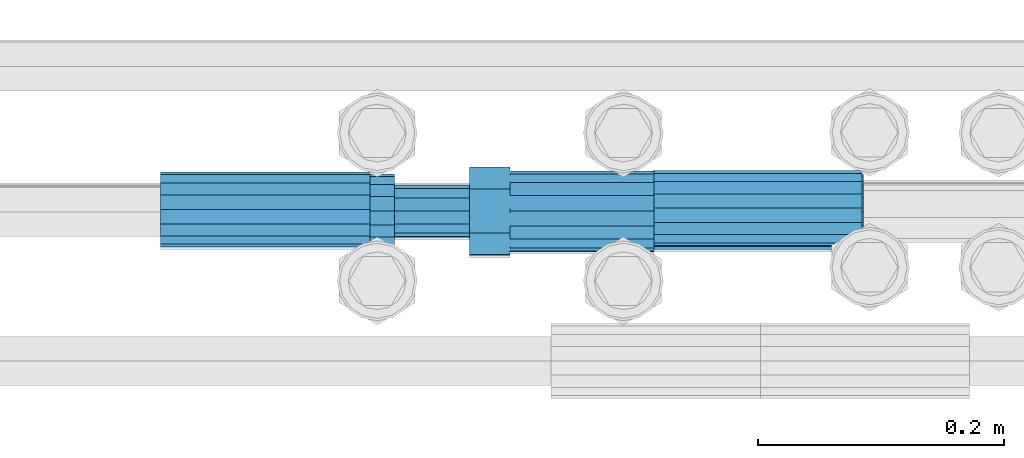
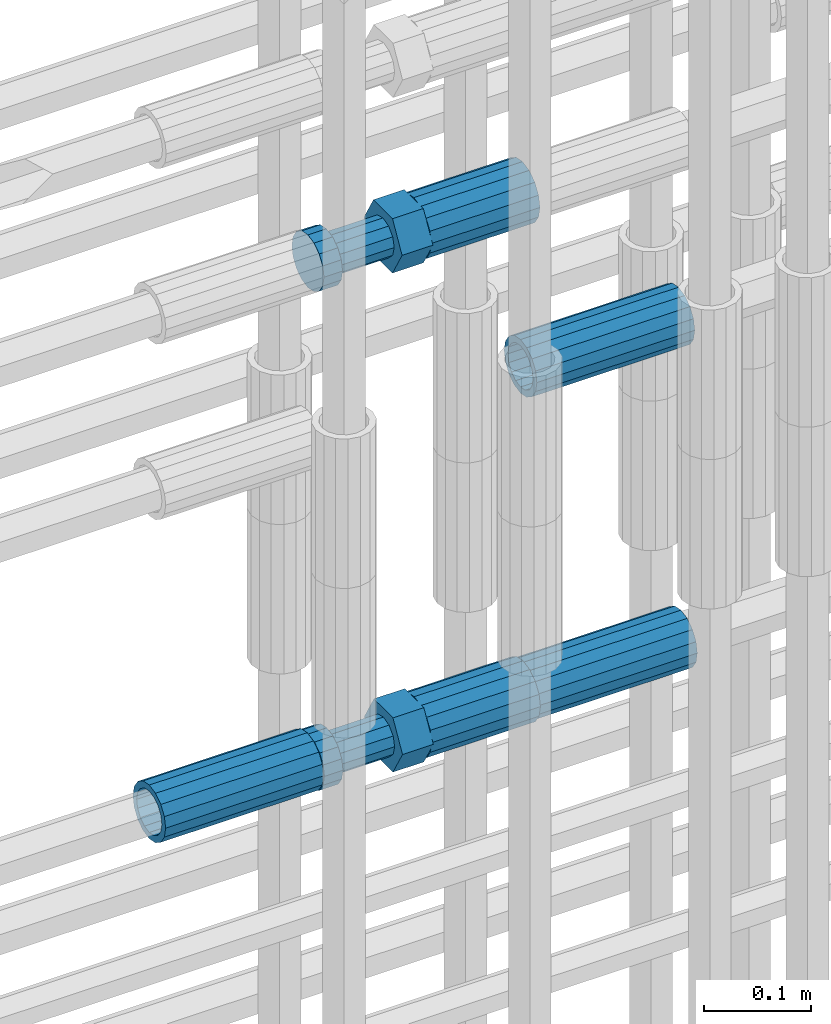
# One storey, part 42 of 119: 5 beams.
"""IFC2X3 building model written with IfcOpenShell, lengths in millimetres."""

from ifc_helpers import new_model, si_unit, frame, origin_with_axes, place, context, subcontext, project, spatial, faceted_brep, material, type_object, element, save


model = new_model("IFC2X3")

# Units and contexts
model_context = context("Model", 3, precision=1e-05, world=origin_with_axes())
body_context = subcontext(model_context, "Body", "Model", "MODEL_VIEW")
ifc_project = project(units=[si_unit("LENGTHUNIT", "METRE", prefix="MILLI"), si_unit("AREAUNIT", "SQUARE_METRE"), si_unit("VOLUMEUNIT", "CUBIC_METRE"), si_unit("MASSUNIT", "GRAM", prefix="KILO"), si_unit("TIMEUNIT", "SECOND"), si_unit("PLANEANGLEUNIT", "RADIAN"), si_unit("SOLIDANGLEUNIT", "STERADIAN"), si_unit("THERMODYNAMICTEMPERATUREUNIT", "DEGREE_CELSIUS"), si_unit("LUMINOUSINTENSITYUNIT", "LUMEN")], contexts=[model_context])

# Site, building, storey
site_placement = place(None, origin_with_axes())
site = spatial("IfcSite", under=ifc_project, at=site_placement, CompositionType="ELEMENT")
building_placement = place(site_placement, origin_with_axes())
building = spatial("IfcBuilding", under=site, at=building_placement, Name="Undefined", CompositionType="ELEMENT")
storey_placement = place(building_placement, origin_with_axes())
storey = spatial("IfcBuildingStorey", under=building, at=storey_placement, Name="Undefined", CompositionType="ELEMENT", Elevation=0.0)

# Beams
ifc_material = material(Name="STEEL/S275")
beam_type_1 = type_object("IfcBeamType", PredefinedType="NOTDEFINED")
beam_1_placement = place(storey_placement, frame((2035518.99345925, 6206284.98777132, 19955.1168409388), z_axis=(0.0, 0.0, 1.0), x_axis=(-0.99999999999998, 1.98000110685822e-07, 0.0)))
element("IfcBeam", 1, at=beam_1_placement, inside=storey, type_object=beam_type_1, material=ifc_material, Name="AG40N", context=body_context, shape_type="Brep", body=[
    faceted_brep([(1.62981450557709e-09, -23.4999999990687, 0.0), (7.45058059692383e-09, -21.7111690142192, 8.99306066057534), (170.000002125278, -21.711168999318, 8.99306066022245), (170.000002127141, -23.4999999844003, -3.66071617463604e-10), (4.65661287307739e-09, -16.6170093587134, 16.6170093578889), (170.000002122484, -16.6170093440451, 16.6170093575288), (1.86264514923096e-09, -8.99306066217832, 21.7111690140277), (170.000002118759, -8.99306064750999, 21.7111690136603), (2.3283064365387e-10, 9.31322574615479e-10, 23.5), (170.000002114102, 1.28056854009628e-08, 23.4999999996485), (-6.51925802230835e-09, 8.99306065868586, 21.7111690140241), (170.00000211224, 8.99306067335419, 21.7111690136639), (-7.45058059692383e-09, 16.6170093561523, 16.6170093578853), (170.000002109446, 16.6170093708206, 16.6170093575324), (-9.31322574615479e-09, 21.711169013055, 8.99306066057534), (170.000002108514, 21.7111690277234, 8.99306066022245), (-1.16415321826935e-09, 23.5000000009313, 0.0), (170.000002108514, 23.5000000144355, -3.66071617463604e-10), (-8.38190317153931e-09, 21.7111690151505, -8.99306066059444), (170.000002110377, 21.7111690300517, -8.9930606609546), (-5.58793544769287e-09, 16.6170093598776, -16.6170093579008), (170.000002113171, 16.6170093745459, -16.6170093582609), (-9.31322574615479e-10, 8.99306066334248, -21.7111690140396), (170.000002115965, 8.99306067801081, -21.7111690143961), (2.3283064365387e-10, 9.31322574615479e-10, -23.5), (170.00000211969, 1.7927959561348e-08, -23.5000000003843), (5.58793544769287e-09, -8.99306065752171, -21.7111690140396), (170.000002123415, -8.99306064285338, -21.7111690143961), (8.38190317153931e-09, -16.6170093549881, -16.6170093579008), (170.000002125278, -16.6170093403198, -16.6170093582646), (9.31322574615479e-09, -21.7111690121237, -8.99306066059444), (170.000002127141, -21.7111689972226, -8.9930606609546), (1.11758708953857e-08, -30.4999999990687, -9.54969436861575e-12), (1.30385160446167e-08, -28.1783257392235, -11.6718446871514), (170.000002129003, -28.1783257243223, -11.6718446875116), (170.000002129935, -30.4999999841675, -3.66071617463604e-10), (1.02445483207703e-08, -21.5667568228673, -21.5667568262129), (170.000002128072, -21.566756808199, -21.5667568265694), (7.45058059692383e-09, -11.6718446831219, -28.1783257416196), (170.000002125278, -11.6718446684536, -28.1783257419834), (3.72529029846191e-09, 3.95812094211578e-09, -30.5000000000277), (170.00000211969, 1.83936208486557e-08, -30.5000000003879), (-9.31322574615479e-10, 11.6718446905725, -28.1783257416232), (170.000002115965, 11.6718447052408, -28.1783257419797), (-6.51925802230835e-09, 21.5667568286881, -21.5667568262093), (170.000002110377, 21.5667568433564, -21.5667568265694), (-9.31322574615479e-09, 28.178325742716, -11.6718446871478), (170.000002108514, 28.1783257573843, -11.6718446875079), (-1.21071934700012e-08, 30.5, -5.91171556152403e-12), (170.000002106652, 30.5000000144355, -3.62433638656512e-10), (-1.21071934700012e-08, 28.1783257401548, 11.6718446871359), (170.00000210572, 28.1783257548232, 11.6718446867794), (-1.02445483207703e-08, 21.5667568240315, 21.5667568261974), (170.000002107583, 21.566756838467, 21.5667568258409), (-7.45058059692383e-09, 11.671844684286, 28.1783257416041), (170.000002110377, 11.6718446989544, 28.178325741244), (-2.79396772384644e-09, -2.56113708019257e-09, 30.5000000000159), (170.000002114102, 1.18743628263474e-08, 30.4999999996558), (1.86264514923096e-09, -11.6718446896411, 28.1783257416114), (170.000002118759, -11.67184467474, 28.178325741244), (7.45058059692383e-09, -21.5667568275239, 21.5667568261974), (170.000002123415, -21.5667568126228, 21.5667568258373), (1.02445483207703e-08, -28.1783257415518, 11.6718446871359), (170.000002127141, -28.1783257271163, 11.6718446867794)], [[[0, 1, 2, 3]], [[1, 4, 5, 2]], [[4, 6, 7, 5]], [[6, 8, 9, 7]], [[8, 10, 11, 9]], [[10, 12, 13, 11]], [[12, 14, 15, 13]], [[14, 16, 17, 15]], [[16, 18, 19, 17]], [[18, 20, 21, 19]], [[20, 22, 23, 21]], [[22, 24, 25, 23]], [[24, 26, 27, 25]], [[26, 28, 29, 27]], [[28, 30, 31, 29]], [[30, 0, 3, 31]], [[32, 33, 34, 35]], [[33, 36, 37, 34]], [[36, 38, 39, 37]], [[38, 40, 41, 39]], [[40, 42, 43, 41]], [[42, 44, 45, 43]], [[44, 46, 47, 45]], [[46, 48, 49, 47]], [[48, 50, 51, 49]], [[50, 52, 53, 51]], [[52, 54, 55, 53]], [[54, 56, 57, 55]], [[56, 58, 59, 57]], [[58, 60, 61, 59]], [[60, 62, 63, 61]], [[62, 32, 35, 63]], [[37, 39, 41, 43, 45, 47, 49, 51, 53, 55, 57, 59, 61, 63, 35, 34], [5, 7, 9, 11, 13, 15, 17, 19, 21, 23, 25, 27, 29, 31, 3, 2]], [[62, 60, 58, 56, 54, 52, 50, 48, 46, 44, 42, 40, 38, 36, 33, 32], [30, 28, 26, 24, 22, 20, 18, 16, 14, 12, 10, 8, 6, 4, 1, 0]]]),
])
beam_2_placement = place(storey_placement, frame((2035519.99345925, 6206282.01777132, 19589.2468409389), z_axis=(0.0, 0.0, 1.0), x_axis=(-0.99999999999998, 1.98000110685822e-07, 0.0)))
element("IfcBeam", 2, at=beam_2_placement, inside=storey, type_object=beam_type_1, material=ifc_material, Name="AG40N", context=body_context, shape_type="Brep", body=[
    faceted_brep([(1.62981450557709e-09, -23.4999999990687, 0.0), (7.45058059692383e-09, -21.7111690142192, 8.99306066057534), (170.000002125278, -21.711168999318, 8.99306066022245), (170.000002127141, -23.4999999844003, -3.66071617463604e-10), (4.65661287307739e-09, -16.6170093587134, 16.6170093578889), (170.000002122484, -16.6170093440451, 16.6170093575288), (1.86264514923096e-09, -8.99306066217832, 21.7111690140277), (170.000002118759, -8.99306064750999, 21.7111690136603), (2.3283064365387e-10, 9.31322574615479e-10, 23.5), (170.000002114102, 1.28056854009628e-08, 23.4999999996485), (-6.51925802230835e-09, 8.99306065868586, 21.7111690140241), (170.00000211224, 8.99306067335419, 21.7111690136639), (-7.45058059692383e-09, 16.6170093561523, 16.6170093578853), (170.000002109446, 16.6170093708206, 16.6170093575324), (-9.31322574615479e-09, 21.711169013055, 8.99306066057534), (170.000002108514, 21.7111690277234, 8.99306066022245), (-1.16415321826935e-09, 23.5000000009313, 0.0), (170.000002108514, 23.5000000144355, -3.66071617463604e-10), (-8.38190317153931e-09, 21.7111690151505, -8.99306066059444), (170.000002110377, 21.7111690300517, -8.9930606609546), (-5.58793544769287e-09, 16.6170093598776, -16.6170093579008), (170.000002113171, 16.6170093745459, -16.6170093582609), (-9.31322574615479e-10, 8.99306066334248, -21.7111690140396), (170.000002115965, 8.99306067801081, -21.7111690143961), (2.3283064365387e-10, 9.31322574615479e-10, -23.5), (170.00000211969, 1.7927959561348e-08, -23.5000000003843), (5.58793544769287e-09, -8.99306065752171, -21.7111690140396), (170.000002123415, -8.99306064285338, -21.7111690143961), (8.38190317153931e-09, -16.6170093549881, -16.6170093579008), (170.000002125278, -16.6170093403198, -16.6170093582646), (9.31322574615479e-09, -21.7111690121237, -8.99306066059444), (170.000002127141, -21.7111689972226, -8.9930606609546), (1.11758708953857e-08, -30.4999999990687, -9.54969436861575e-12), (1.30385160446167e-08, -28.1783257392235, -11.6718446871514), (170.000002129003, -28.1783257243223, -11.6718446875116), (170.000002129935, -30.4999999841675, -3.66071617463604e-10), (1.02445483207703e-08, -21.5667568228673, -21.5667568262129), (170.000002128072, -21.566756808199, -21.5667568265694), (7.45058059692383e-09, -11.6718446831219, -28.1783257416196), (170.000002125278, -11.6718446684536, -28.1783257419834), (3.72529029846191e-09, 3.95812094211578e-09, -30.5000000000277), (170.00000211969, 1.83936208486557e-08, -30.5000000003879), (-9.31322574615479e-10, 11.6718446905725, -28.1783257416232), (170.000002115965, 11.6718447052408, -28.1783257419797), (-6.51925802230835e-09, 21.5667568286881, -21.5667568262093), (170.000002110377, 21.5667568433564, -21.5667568265694), (-9.31322574615479e-09, 28.178325742716, -11.6718446871478), (170.000002108514, 28.1783257573843, -11.6718446875079), (-1.21071934700012e-08, 30.5, -5.91171556152403e-12), (170.000002106652, 30.5000000144355, -3.62433638656512e-10), (-1.21071934700012e-08, 28.1783257401548, 11.6718446871359), (170.00000210572, 28.1783257548232, 11.6718446867794), (-1.02445483207703e-08, 21.5667568240315, 21.5667568261974), (170.000002107583, 21.566756838467, 21.5667568258409), (-7.45058059692383e-09, 11.671844684286, 28.1783257416041), (170.000002110377, 11.6718446989544, 28.178325741244), (-2.79396772384644e-09, -2.56113708019257e-09, 30.5000000000159), (170.000002114102, 1.18743628263474e-08, 30.4999999996558), (1.86264514923096e-09, -11.6718446896411, 28.1783257416114), (170.000002118759, -11.67184467474, 28.178325741244), (7.45058059692383e-09, -21.5667568275239, 21.5667568261974), (170.000002123415, -21.5667568126228, 21.5667568258373), (1.02445483207703e-08, -28.1783257415518, 11.6718446871359), (170.000002127141, -28.1783257271163, 11.6718446867794)], [[[0, 1, 2, 3]], [[1, 4, 5, 2]], [[4, 6, 7, 5]], [[6, 8, 9, 7]], [[8, 10, 11, 9]], [[10, 12, 13, 11]], [[12, 14, 15, 13]], [[14, 16, 17, 15]], [[16, 18, 19, 17]], [[18, 20, 21, 19]], [[20, 22, 23, 21]], [[22, 24, 25, 23]], [[24, 26, 27, 25]], [[26, 28, 29, 27]], [[28, 30, 31, 29]], [[30, 0, 3, 31]], [[32, 33, 34, 35]], [[33, 36, 37, 34]], [[36, 38, 39, 37]], [[38, 40, 41, 39]], [[40, 42, 43, 41]], [[42, 44, 45, 43]], [[44, 46, 47, 45]], [[46, 48, 49, 47]], [[48, 50, 51, 49]], [[50, 52, 53, 51]], [[52, 54, 55, 53]], [[54, 56, 57, 55]], [[56, 58, 59, 57]], [[58, 60, 61, 59]], [[60, 62, 63, 61]], [[62, 32, 35, 63]], [[37, 39, 41, 43, 45, 47, 49, 51, 53, 55, 57, 59, 61, 63, 35, 34], [5, 7, 9, 11, 13, 15, 17, 19, 21, 23, 25, 27, 29, 31, 3, 2]], [[62, 60, 58, 56, 54, 52, 50, 48, 46, 44, 42, 40, 38, 36, 33, 32], [30, 28, 26, 24, 22, 20, 18, 16, 14, 12, 10, 8, 6, 4, 1, 0]]]),
])
beam_3_placement = place(storey_placement, frame((2034949.03023304, 6206283.98994599, 19588.9894131571), z_axis=(0.0, 0.0, 1.0), x_axis=(1.0, 0.0, 0.0)))
element("IfcBeam", 3, at=beam_3_placement, inside=storey, type_object=beam_type_1, material=ifc_material, Name="AG40N", context=body_context, shape_type="Brep", body=[
    faceted_brep([(1.62981450557709e-09, -23.4999999990687, 0.0), (7.45058059692383e-09, -21.7111690142192, 8.99306066057534), (170.000002125278, -21.711168999318, 8.99306066022245), (170.000002127141, -23.4999999844003, -3.66071617463604e-10), (4.65661287307739e-09, -16.6170093587134, 16.6170093578889), (170.000002122484, -16.6170093440451, 16.6170093575288), (1.86264514923096e-09, -8.99306066217832, 21.7111690140277), (170.000002118759, -8.99306064750999, 21.7111690136603), (2.3283064365387e-10, 9.31322574615479e-10, 23.5), (170.000002114102, 1.28056854009628e-08, 23.4999999996485), (-6.51925802230835e-09, 8.99306065868586, 21.7111690140241), (170.00000211224, 8.99306067335419, 21.7111690136639), (-7.45058059692383e-09, 16.6170093561523, 16.6170093578853), (170.000002109446, 16.6170093708206, 16.6170093575324), (-9.31322574615479e-09, 21.711169013055, 8.99306066057534), (170.000002108514, 21.7111690277234, 8.99306066022245), (-1.16415321826935e-09, 23.5000000009313, 0.0), (170.000002108514, 23.5000000144355, -3.66071617463604e-10), (-8.38190317153931e-09, 21.7111690151505, -8.99306066059444), (170.000002110377, 21.7111690300517, -8.9930606609546), (-5.58793544769287e-09, 16.6170093598776, -16.6170093579008), (170.000002113171, 16.6170093745459, -16.6170093582609), (-9.31322574615479e-10, 8.99306066334248, -21.7111690140396), (170.000002115965, 8.99306067801081, -21.7111690143961), (2.3283064365387e-10, 9.31322574615479e-10, -23.5), (170.00000211969, 1.7927959561348e-08, -23.5000000003843), (5.58793544769287e-09, -8.99306065752171, -21.7111690140396), (170.000002123415, -8.99306064285338, -21.7111690143961), (8.38190317153931e-09, -16.6170093549881, -16.6170093579008), (170.000002125278, -16.6170093403198, -16.6170093582646), (9.31322574615479e-09, -21.7111690121237, -8.99306066059444), (170.000002127141, -21.7111689972226, -8.9930606609546), (1.11758708953857e-08, -30.4999999990687, -9.54969436861575e-12), (1.30385160446167e-08, -28.1783257392235, -11.6718446871514), (170.000002129003, -28.1783257243223, -11.6718446875116), (170.000002129935, -30.4999999841675, -3.66071617463604e-10), (1.02445483207703e-08, -21.5667568228673, -21.5667568262129), (170.000002128072, -21.566756808199, -21.5667568265694), (7.45058059692383e-09, -11.6718446831219, -28.1783257416196), (170.000002125278, -11.6718446684536, -28.1783257419834), (3.72529029846191e-09, 3.95812094211578e-09, -30.5000000000277), (170.00000211969, 1.83936208486557e-08, -30.5000000003879), (-9.31322574615479e-10, 11.6718446905725, -28.1783257416232), (170.000002115965, 11.6718447052408, -28.1783257419797), (-6.51925802230835e-09, 21.5667568286881, -21.5667568262093), (170.000002110377, 21.5667568433564, -21.5667568265694), (-9.31322574615479e-09, 28.178325742716, -11.6718446871478), (170.000002108514, 28.1783257573843, -11.6718446875079), (-1.21071934700012e-08, 30.5, -5.91171556152403e-12), (170.000002106652, 30.5000000144355, -3.62433638656512e-10), (-1.21071934700012e-08, 28.1783257401548, 11.6718446871359), (170.00000210572, 28.1783257548232, 11.6718446867794), (-1.02445483207703e-08, 21.5667568240315, 21.5667568261974), (170.000002107583, 21.566756838467, 21.5667568258409), (-7.45058059692383e-09, 11.671844684286, 28.1783257416041), (170.000002110377, 11.6718446989544, 28.178325741244), (-2.79396772384644e-09, -2.56113708019257e-09, 30.5000000000159), (170.000002114102, 1.18743628263474e-08, 30.4999999996558), (1.86264514923096e-09, -11.6718446896411, 28.1783257416114), (170.000002118759, -11.67184467474, 28.178325741244), (7.45058059692383e-09, -21.5667568275239, 21.5667568261974), (170.000002123415, -21.5667568126228, 21.5667568258373), (1.02445483207703e-08, -28.1783257415518, 11.6718446871359), (170.000002127141, -28.1783257271163, 11.6718446867794)], [[[0, 1, 2, 3]], [[1, 4, 5, 2]], [[4, 6, 7, 5]], [[6, 8, 9, 7]], [[8, 10, 11, 9]], [[10, 12, 13, 11]], [[12, 14, 15, 13]], [[14, 16, 17, 15]], [[16, 18, 19, 17]], [[18, 20, 21, 19]], [[20, 22, 23, 21]], [[22, 24, 25, 23]], [[24, 26, 27, 25]], [[26, 28, 29, 27]], [[28, 30, 31, 29]], [[30, 0, 3, 31]], [[32, 33, 34, 35]], [[33, 36, 37, 34]], [[36, 38, 39, 37]], [[38, 40, 41, 39]], [[40, 42, 43, 41]], [[42, 44, 45, 43]], [[44, 46, 47, 45]], [[46, 48, 49, 47]], [[48, 50, 51, 49]], [[50, 52, 53, 51]], [[52, 54, 55, 53]], [[54, 56, 57, 55]], [[56, 58, 59, 57]], [[58, 60, 61, 59]], [[60, 62, 63, 61]], [[62, 32, 35, 63]], [[37, 39, 41, 43, 45, 47, 49, 51, 53, 55, 57, 59, 61, 63, 35, 34], [5, 7, 9, 11, 13, 15, 17, 19, 21, 23, 25, 27, 29, 31, 3, 2]], [[62, 60, 58, 56, 54, 52, 50, 48, 46, 44, 42, 40, 38, 36, 33, 32], [30, 28, 26, 24, 22, 20, 18, 16, 14, 12, 10, 8, 6, 4, 1, 0]]]),
])
beam_type_2 = type_object("IfcBeamType", Name="ROD65", PredefinedType="NOTDEFINED")
beam_4_placement = place(storey_placement, frame((2035349.99345925, 6206282.82777132, 20156.4668409387), z_axis=(0.0, 0.0, 1.0), x_axis=(-0.99999999999998, 1.98000110685822e-07, 0.0)))
element("IfcBeam", 4, at=beam_4_placement, inside=storey, type_object=beam_type_2, material=ifc_material, Name="AGB40", ObjectType="ROD65", context=body_context, shape_type="Brep", body=[
    faceted_brep([(116.999999999069, 17.8249999252148, 30.8738056446964), (116.999999998137, 22.0056957420893, 23.632628078838), (116.999999999069, 12.4372115600854, 30.0260848066173), (116.999999999069, 8.17543111252598, 30.8738056446964), (117.000000000931, -17.8250000746921, 30.8738056446964), (150.200000001118, -17.8250000723638, 30.8738056446964), (150.199999999255, 17.8249999275431, 30.8738056446964), (117.000000000931, -8.17543109622784, 30.8738056446964), (117.000000001863, -22.0056959956419, 23.6326278985034), (117.000000000931, -12.4372115437873, 30.0260848066173), (117.000000001863, -35.6500000746455, -2.18278728425503e-10), (150.200000002049, -35.6500000723172, -2.18278728425503e-10), (117.000000001863, -30.8443149488885, 8.32369080289209), (117.000000001863, -30.8443149488885, -8.32369080355784), (117.000000002794, -32.4999999918509, 0.0), (117.000000000931, -17.8250000746921, -30.873805645133), (150.200000001118, -17.8250000723638, -30.873805645133), (117.000000001863, -22.0056959961075, -23.6326278982269), (117.000000000931, -8.17543109389953, -30.873805645133), (117.000000000931, -12.4372115437873, -30.0260848066173), (116.999999999069, 17.8249999252148, -30.873805645133), (150.199999999255, 17.8249999275431, -30.873805645133), (116.999999999069, 8.17543111019768, -30.873805645133), (116.999999999069, 12.4372115600854, -30.0260848066173), (116.999999998137, 22.005695742555, -23.6326280785652), (116.999999998137, 35.6499999251682, -2.18278728425503e-10), (150.199999998324, 35.6499999277294, -2.18278728425503e-10), (116.999999998137, 30.8443150522653, -8.32369036550881), (116.999999997206, 32.5000000081491, 0.0), (116.999999998137, 30.8443150522653, 8.32369036483942), (1.86264514923096e-09, -22.9809703885112, 22.9809703885621), (1.86264514923096e-09, -30.0260848065373, 12.4372115518672), (117.000000001863, -30.0260847983882, 12.4372115518672), (117.000000001863, -22.9809703803621, 22.9809703885621), (-1.86264514923096e-09, 22.9809703885112, -22.9809703885621), (-1.86264514923096e-09, 30.0260848065373, -12.4372115518672), (116.999999998137, 30.0260848146863, -12.4372115518672), (116.999999998137, 22.9809703966603, -22.9809703885621), (1.86264514923096e-09, -30.0260848065373, -12.4372115518672), (1.86264514923096e-09, -22.9809703885112, -22.9809703885621), (117.000000001863, -22.9809703803621, -22.9809703885621), (117.000000001863, -30.0260847983882, -12.4372115518672), (9.31322574615479e-10, -12.4372115519363, 30.0260848066173), (0.0, 0.0, 32.5), (-9.31322574615479e-10, 12.4372115519363, 30.0260848066173), (-1.86264514923096e-09, 22.9809703885112, 22.9809703885621), (-1.86264514923096e-09, 30.0260848065373, 12.4372115518672), (-2.79396772384644e-09, 32.5, 0.0), (-9.31322574615479e-10, 12.4372115519363, -30.0260848066173), (0.0, 0.0, -32.5), (9.31322574615479e-10, -12.4372115519363, -30.0260848066173), (2.79396772384644e-09, -32.5, 0.0), (116.999999998137, 22.9809703966603, 22.9809703885621), (116.999999998137, 30.0260848146863, 12.4372115518672), (117.0, 8.14907252788544e-09, -32.5), (117.0, 8.14907252788544e-09, 32.5), (150.200000000186, -10.5000000959262, 18.1865334791873), (150.199999999255, -9.59262251853943e-08, 20.9999999997126), (150.199999998324, 10.4999999040738, 18.1865334791873), (150.199999997392, 18.1865333835594, 10.4999999997126), (150.199999997392, 20.9999999040738, -2.87400325760245e-10), (150.199999997392, 18.1865333835594, -10.5000000002874), (150.199999998324, 10.4999999040738, -18.1865334797621), (150.199999999255, -9.59262251853943e-08, -21.0000000002874), (150.200000000186, -10.5000000959262, -18.1865334797621), (150.200000000186, -18.1865335754119, -10.5000000002874), (150.200000001118, -21.0000000959262, -2.87400325760245e-10), (150.200000000186, -18.1865335754119, 10.4999999997126), (210.979999999516, 10.4999999082647, 18.1865334791873), (210.979999999516, -9.17352735996246e-08, 20.9999999997126), (210.979999997653, 18.1865333877504, 10.4999999997126), (210.979999997653, 20.9999999082647, -2.87400325760245e-10), (210.979999997653, 18.1865333877504, -10.5000000002874), (210.979999999516, 10.4999999082647, -18.1865334797621), (210.979999999516, -9.17352735996246e-08, -21.0000000002874), (210.979999999516, -10.5000000917353, -18.1865334797621), (210.980000000447, -18.1865335712209, -10.5000000002874), (210.980000001378, -21.0000000917353, -2.87400325760245e-10), (210.980000000447, -18.1865335712209, 10.4999999997126), (210.979999999516, -10.5000000917353, 18.1865334791873), (211.001368402503, -27.7269939335529, -11.4911163272045), (211.003082515672, -21.2238095656503, -21.2238154190527), (231.002518340945, -21.2131946226582, -21.2132004554769), (231.000804228708, -27.7163789905608, -11.4805013636287), (211.001368415542, -11.4911086384673, -27.7269970399575), (231.000804241747, -11.4804936954752, -27.7163820763781), (210.996487061493, -0.0106066407170147, -30.0106107396168), (230.995922887698, 8.30227509140968e-06, -29.999995776041), (210.98918159306, 11.4698940692469, -27.7269970332745), (230.988617419265, 11.4805090120062, -27.7163820696951), (210.980564201251, 21.2025913291145, -21.2238154067054), (230.980000027455, 21.2132062721066, -21.2132004431296), (210.971946807578, 27.7057702087332, -11.4911163110701), (230.971382633783, 27.7163851517253, -11.4805013474943), (210.964641331695, 29.9893806746695, -0.0106149565435771), (230.9640771579, 29.9999956176616, 7.03221303410828e-09), (210.959759964608, 27.7057637346443, 11.4698863966551), (230.959195790812, 27.7163786776364, 11.4805013602345), (210.958045851439, 21.2025793667417, 21.2025854885032), (230.957481677644, 21.2131943097338, 21.2132004520827), (210.959759951569, 11.4698784395587, 27.705767109408), (230.959195776843, 11.4804933823179, 27.7163820729838), (210.964641305618, -0.0106235581915826, 29.9893808090674), (230.964077131823, -8.61519947648048e-06, 29.9999957726432), (210.971946774051, -11.4911242681555, 27.7057671027251), (230.971382599324, -11.4805093251634, 27.7163820663009), (210.98056416586, -21.2238215280231, 21.2025854761559), (230.979999991134, -21.2132065852638, 21.2132004397354), (210.989181559533, -27.7270004076418, 11.4698863805206), (230.988617384806, -27.7163854646496, 11.4805013441), (210.996487035416, -30.0106108735781, -0.0106149740058754), (230.995922861621, -29.999995930586, -1.04300852399319e-08)], [[[0, 1, 2, 3]], [[4, 5, 6, 0, 3, 7]], [[8, 4, 7, 9]], [[10, 11, 5, 4, 8, 12]], [[13, 10, 12, 14]], [[15, 16, 11, 10, 13, 17]], [[18, 15, 17, 19]], [[20, 21, 16, 15, 18, 22]], [[20, 22, 23, 24]], [[25, 26, 21, 20, 24, 27]], [[25, 27, 28, 29]], [[30, 31, 32, 33]], [[34, 35, 36, 37]], [[38, 39, 40, 41]], [[31, 30, 42, 43, 44, 45, 46, 47, 35, 34, 48, 49, 50, 39, 38, 51]], [[46, 45, 52, 53]], [[28, 47, 46, 53, 29]], [[27, 36, 35, 47, 28]], [[24, 37, 36, 27]], [[23, 48, 34, 37, 24]], [[22, 54, 49, 48, 23]], [[18, 54, 22]], [[19, 50, 49, 54, 18]], [[17, 40, 39, 50, 19]], [[13, 41, 40, 17]], [[14, 51, 38, 41, 13]], [[12, 32, 31, 51, 14]], [[8, 33, 32, 12]], [[9, 42, 30, 33, 8]], [[7, 55, 43, 42, 9]], [[3, 55, 7]], [[2, 44, 43, 55, 3]], [[1, 52, 45, 44, 2]], [[29, 53, 52, 1]], [[0, 6, 26, 25, 29, 1]], [[5, 11, 16, 21, 26, 6], [56, 57, 58, 59, 60, 61, 62, 63, 64, 65, 66, 67]], [[68, 58, 57, 69]], [[70, 59, 58, 68]], [[71, 60, 59, 70]], [[72, 61, 60, 71]], [[73, 62, 61, 72]], [[74, 63, 62, 73]], [[75, 64, 63, 74]], [[76, 65, 64, 75]], [[77, 66, 65, 76]], [[78, 67, 66, 77]], [[79, 56, 67, 78]], [[69, 57, 56, 79]], [[80, 81, 82, 83]], [[81, 84, 85, 82]], [[84, 86, 87, 85]], [[86, 88, 89, 87]], [[88, 90, 91, 89]], [[90, 92, 93, 91]], [[92, 94, 95, 93]], [[94, 96, 97, 95]], [[96, 98, 99, 97]], [[98, 100, 101, 99]], [[100, 102, 103, 101]], [[102, 104, 105, 103]], [[104, 106, 107, 105]], [[106, 108, 109, 107]], [[108, 110, 111, 109]], [[82, 85, 87, 89, 91, 93, 95, 97, 99, 101, 103, 105, 107, 109, 111, 83]], [[110, 80, 83, 111]], [[108, 106, 104, 102, 100, 98, 96, 94, 92, 90, 88, 86, 84, 81, 80, 110], [78, 77, 76, 75, 74, 73, 72, 71, 70, 68, 69, 79]]]),
])
beam_5_placement = place(storey_placement, frame((2035349.99345925, 6206282.01777132, 19589.2468409388), z_axis=(0.0, 0.0, 1.0), x_axis=(-0.99999999999998, 1.98000110685822e-07, 0.0)))
element("IfcBeam", 5, at=beam_5_placement, inside=storey, type_object=beam_type_2, material=ifc_material, Name="AGB40", ObjectType="ROD65", context=body_context, shape_type="Brep", body=[
    faceted_brep([(116.999999999069, 17.8249999252148, 30.8738056446964), (116.999999998137, 22.0056957420893, 23.632628078838), (116.999999999069, 12.4372115600854, 30.0260848066173), (116.999999999069, 8.17543111252598, 30.8738056446964), (117.000000000931, -17.8250000746921, 30.8738056446964), (150.200000001118, -17.8250000723638, 30.8738056446964), (150.199999999255, 17.8249999275431, 30.8738056446964), (117.000000000931, -8.17543109622784, 30.8738056446964), (117.000000001863, -22.0056959956419, 23.6326278985034), (117.000000000931, -12.4372115437873, 30.0260848066173), (117.000000001863, -35.6500000746455, -2.18278728425503e-10), (150.200000002049, -35.6500000723172, -2.18278728425503e-10), (117.000000001863, -30.8443149488885, 8.32369080289209), (117.000000001863, -30.8443149488885, -8.32369080355784), (117.000000002794, -32.4999999918509, 0.0), (117.000000000931, -17.8250000746921, -30.873805645133), (150.200000001118, -17.8250000723638, -30.873805645133), (117.000000001863, -22.0056959961075, -23.6326278982269), (117.000000000931, -8.17543109389953, -30.873805645133), (117.000000000931, -12.4372115437873, -30.0260848066173), (116.999999999069, 17.8249999252148, -30.873805645133), (150.199999999255, 17.8249999275431, -30.873805645133), (116.999999999069, 8.17543111019768, -30.873805645133), (116.999999999069, 12.4372115600854, -30.0260848066173), (116.999999998137, 22.005695742555, -23.6326280785652), (116.999999998137, 35.6499999251682, -2.18278728425503e-10), (150.199999998324, 35.6499999277294, -2.18278728425503e-10), (116.999999998137, 30.8443150522653, -8.32369036550881), (116.999999997206, 32.5000000081491, 0.0), (116.999999998137, 30.8443150522653, 8.32369036483942), (1.86264514923096e-09, -22.9809703885112, 22.9809703885621), (1.86264514923096e-09, -30.0260848065373, 12.4372115518672), (117.000000001863, -30.0260847983882, 12.4372115518672), (117.000000001863, -22.9809703803621, 22.9809703885621), (-1.86264514923096e-09, 22.9809703885112, -22.9809703885621), (-1.86264514923096e-09, 30.0260848065373, -12.4372115518672), (116.999999998137, 30.0260848146863, -12.4372115518672), (116.999999998137, 22.9809703966603, -22.9809703885621), (1.86264514923096e-09, -30.0260848065373, -12.4372115518672), (1.86264514923096e-09, -22.9809703885112, -22.9809703885621), (117.000000001863, -22.9809703803621, -22.9809703885621), (117.000000001863, -30.0260847983882, -12.4372115518672), (9.31322574615479e-10, -12.4372115519363, 30.0260848066173), (0.0, 0.0, 32.5), (-9.31322574615479e-10, 12.4372115519363, 30.0260848066173), (-1.86264514923096e-09, 22.9809703885112, 22.9809703885621), (-1.86264514923096e-09, 30.0260848065373, 12.4372115518672), (-2.79396772384644e-09, 32.5, 0.0), (-9.31322574615479e-10, 12.4372115519363, -30.0260848066173), (0.0, 0.0, -32.5), (9.31322574615479e-10, -12.4372115519363, -30.0260848066173), (2.79396772384644e-09, -32.5, 0.0), (116.999999998137, 22.9809703966603, 22.9809703885621), (116.999999998137, 30.0260848146863, 12.4372115518672), (117.0, 8.14907252788544e-09, -32.5), (117.0, 8.14907252788544e-09, 32.5), (150.200000000186, -10.5000000959262, 18.1865334791873), (150.199999999255, -9.59262251853943e-08, 20.9999999997126), (150.199999998324, 10.4999999040738, 18.1865334791873), (150.199999997392, 18.1865333835594, 10.4999999997126), (150.199999997392, 20.9999999040738, -2.87400325760245e-10), (150.199999997392, 18.1865333835594, -10.5000000002874), (150.199999998324, 10.4999999040738, -18.1865334797621), (150.199999999255, -9.59262251853943e-08, -21.0000000002874), (150.200000000186, -10.5000000959262, -18.1865334797621), (150.200000000186, -18.1865335754119, -10.5000000002874), (150.200000001118, -21.0000000959262, -2.87400325760245e-10), (150.200000000186, -18.1865335754119, 10.4999999997126), (210.979999999516, 10.4999999082647, 18.1865334791873), (210.979999999516, -9.17352735996246e-08, 20.9999999997126), (210.979999997653, 18.1865333877504, 10.4999999997126), (210.979999997653, 20.9999999082647, -2.87400325760245e-10), (210.979999997653, 18.1865333877504, -10.5000000002874), (210.979999999516, 10.4999999082647, -18.1865334797621), (210.979999999516, -9.17352735996246e-08, -21.0000000002874), (210.979999999516, -10.5000000917353, -18.1865334797621), (210.980000000447, -18.1865335712209, -10.5000000002874), (210.980000001378, -21.0000000917353, -2.87400325760245e-10), (210.980000000447, -18.1865335712209, 10.4999999997126), (210.979999999516, -10.5000000917353, 18.1865334791873), (211.001368402503, -27.7269939335529, -11.4911163272045), (211.003082515672, -21.2238095656503, -21.2238154190527), (231.002518340945, -21.2131946226582, -21.2132004554769), (231.000804228708, -27.7163789905608, -11.4805013636287), (211.001368415542, -11.4911086384673, -27.7269970399575), (231.000804241747, -11.4804936954752, -27.7163820763781), (210.996487061493, -0.0106066407170147, -30.0106107396168), (230.995922887698, 8.30227509140968e-06, -29.999995776041), (210.98918159306, 11.4698940692469, -27.7269970332745), (230.988617419265, 11.4805090120062, -27.7163820696951), (210.980564201251, 21.2025913291145, -21.2238154067054), (230.980000027455, 21.2132062721066, -21.2132004431296), (210.971946807578, 27.7057702087332, -11.4911163110701), (230.971382633783, 27.7163851517253, -11.4805013474943), (210.964641331695, 29.9893806746695, -0.0106149565435771), (230.9640771579, 29.9999956176616, 7.03221303410828e-09), (210.959759964608, 27.7057637346443, 11.4698863966551), (230.959195790812, 27.7163786776364, 11.4805013602345), (210.958045851439, 21.2025793667417, 21.2025854885032), (230.957481677644, 21.2131943097338, 21.2132004520827), (210.959759951569, 11.4698784395587, 27.705767109408), (230.959195776843, 11.4804933823179, 27.7163820729838), (210.964641305618, -0.0106235581915826, 29.9893808090674), (230.964077131823, -8.61519947648048e-06, 29.9999957726432), (210.971946774051, -11.4911242681555, 27.7057671027251), (230.971382599324, -11.4805093251634, 27.7163820663009), (210.98056416586, -21.2238215280231, 21.2025854761559), (230.979999991134, -21.2132065852638, 21.2132004397354), (210.989181559533, -27.7270004076418, 11.4698863805206), (230.988617384806, -27.7163854646496, 11.4805013441), (210.996487035416, -30.0106108735781, -0.0106149740058754), (230.995922861621, -29.999995930586, -1.04300852399319e-08)], [[[0, 1, 2, 3]], [[4, 5, 6, 0, 3, 7]], [[8, 4, 7, 9]], [[10, 11, 5, 4, 8, 12]], [[13, 10, 12, 14]], [[15, 16, 11, 10, 13, 17]], [[18, 15, 17, 19]], [[20, 21, 16, 15, 18, 22]], [[20, 22, 23, 24]], [[25, 26, 21, 20, 24, 27]], [[25, 27, 28, 29]], [[30, 31, 32, 33]], [[34, 35, 36, 37]], [[38, 39, 40, 41]], [[31, 30, 42, 43, 44, 45, 46, 47, 35, 34, 48, 49, 50, 39, 38, 51]], [[46, 45, 52, 53]], [[28, 47, 46, 53, 29]], [[27, 36, 35, 47, 28]], [[24, 37, 36, 27]], [[23, 48, 34, 37, 24]], [[22, 54, 49, 48, 23]], [[18, 54, 22]], [[19, 50, 49, 54, 18]], [[17, 40, 39, 50, 19]], [[13, 41, 40, 17]], [[14, 51, 38, 41, 13]], [[12, 32, 31, 51, 14]], [[8, 33, 32, 12]], [[9, 42, 30, 33, 8]], [[7, 55, 43, 42, 9]], [[3, 55, 7]], [[2, 44, 43, 55, 3]], [[1, 52, 45, 44, 2]], [[29, 53, 52, 1]], [[0, 6, 26, 25, 29, 1]], [[5, 11, 16, 21, 26, 6], [56, 57, 58, 59, 60, 61, 62, 63, 64, 65, 66, 67]], [[68, 58, 57, 69]], [[70, 59, 58, 68]], [[71, 60, 59, 70]], [[72, 61, 60, 71]], [[73, 62, 61, 72]], [[74, 63, 62, 73]], [[75, 64, 63, 74]], [[76, 65, 64, 75]], [[77, 66, 65, 76]], [[78, 67, 66, 77]], [[79, 56, 67, 78]], [[69, 57, 56, 79]], [[80, 81, 82, 83]], [[81, 84, 85, 82]], [[84, 86, 87, 85]], [[86, 88, 89, 87]], [[88, 90, 91, 89]], [[90, 92, 93, 91]], [[92, 94, 95, 93]], [[94, 96, 97, 95]], [[96, 98, 99, 97]], [[98, 100, 101, 99]], [[100, 102, 103, 101]], [[102, 104, 105, 103]], [[104, 106, 107, 105]], [[106, 108, 109, 107]], [[108, 110, 111, 109]], [[82, 85, 87, 89, 91, 93, 95, 97, 99, 101, 103, 105, 107, 109, 111, 83]], [[110, 80, 83, 111]], [[108, 106, 104, 102, 100, 98, 96, 94, 92, 90, 88, 86, 84, 81, 80, 110], [78, 77, 76, 75, 74, 73, 72, 71, 70, 68, 69, 79]]]),
])

save(model, "model.ifc")
